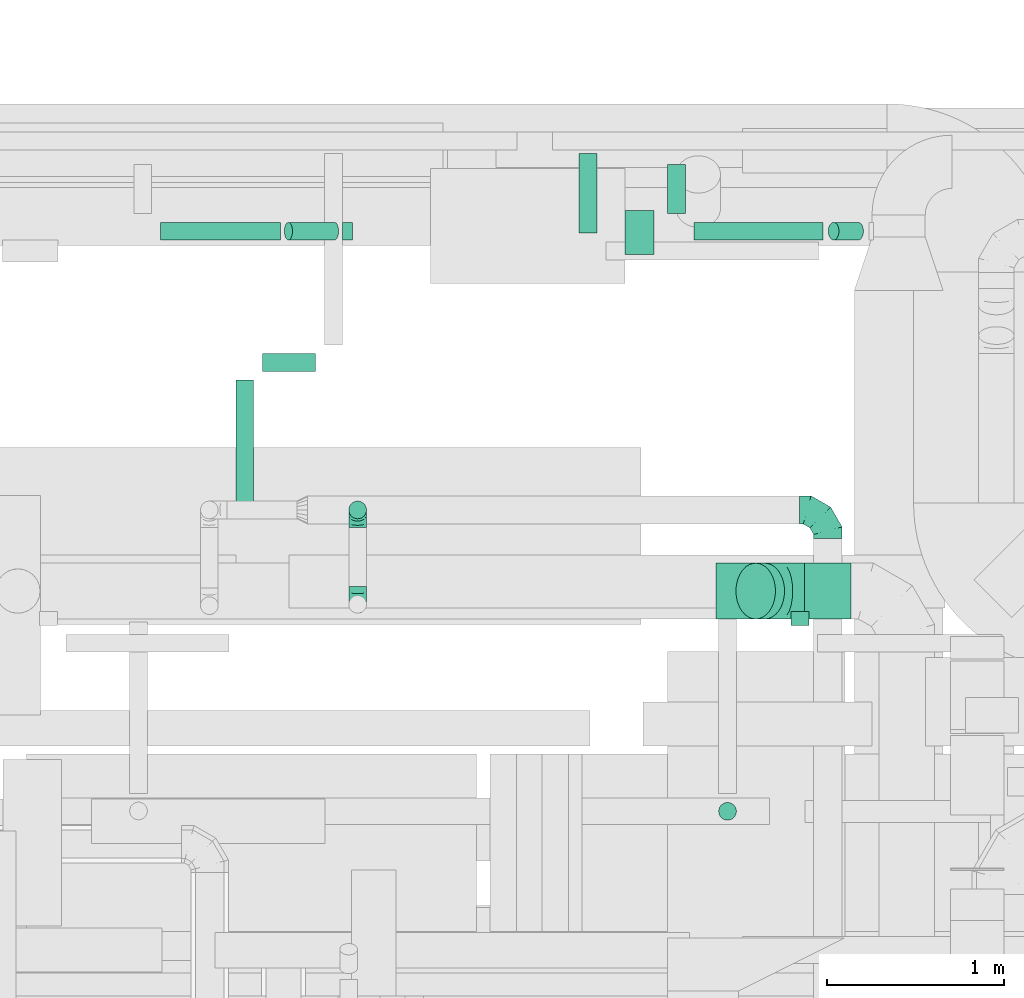
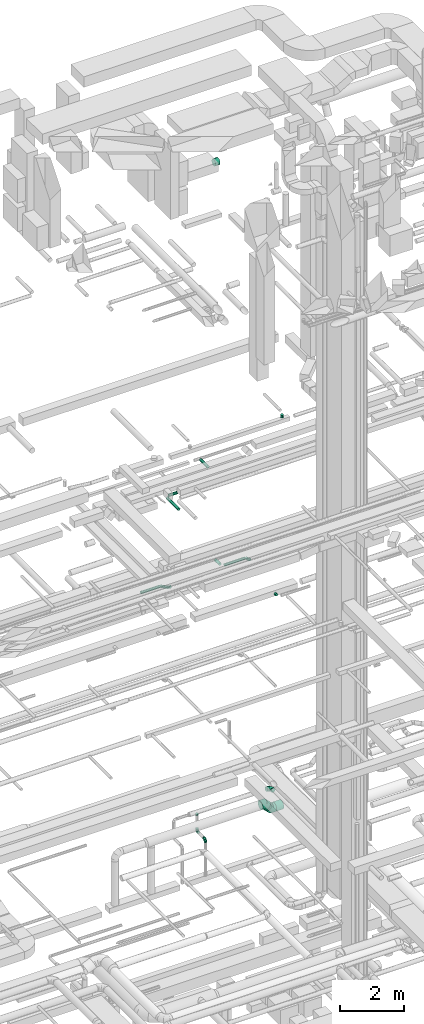
# One storey, part 277 of 337: 14 flow segments, 6 flow fittings.
"""IFC2X3 building model written with IfcOpenShell, lengths in millimetres."""

from ifc_helpers import new_model, entity, si_unit, converted_unit, derived_unit, direction, frame, origin, origin_2d_with_axis, place, context, subcontext, project, spatial, circle, extrude, faceted_brep, source, transform, mapped, material, type_object, type_shapes, element, save


model = new_model("IFC2X3")

# Units and contexts
model_context = context("Model", 3, precision=0.01, world=origin(), true_north=direction((6.12303176911189e-17, 1.0)))
body_context = subcontext(model_context, "Body", "Model", "MODEL_VIEW")
ifc_project = project(units=[si_unit("LENGTHUNIT", "METRE", prefix="MILLI"), si_unit("AREAUNIT", "SQUARE_METRE"), si_unit("VOLUMEUNIT", "CUBIC_METRE"), converted_unit("PLANEANGLEUNIT", "DEGREE", entity("IfcRatioMeasure", 0.0174532925199433), si_unit("PLANEANGLEUNIT", "RADIAN"), dimensions=[0, 0, 0, 0, 0, 0, 0]), si_unit("MASSUNIT", "GRAM", prefix="KILO"), derived_unit("MASSDENSITYUNIT", [(si_unit("MASSUNIT", "GRAM", prefix="KILO"), 1), (si_unit("LENGTHUNIT", "METRE"), -3)]), derived_unit("MOMENTOFINERTIAUNIT", [(si_unit("LENGTHUNIT", "METRE"), 4)]), si_unit("TIMEUNIT", "SECOND"), si_unit("FREQUENCYUNIT", "HERTZ"), si_unit("THERMODYNAMICTEMPERATUREUNIT", "DEGREE_CELSIUS"), derived_unit("THERMALTRANSMITTANCEUNIT", [(si_unit("MASSUNIT", "GRAM", prefix="KILO"), 1), (si_unit("THERMODYNAMICTEMPERATUREUNIT", "KELVIN"), -1), (si_unit("TIMEUNIT", "SECOND"), -3)]), derived_unit("VOLUMETRICFLOWRATEUNIT", [(si_unit("LENGTHUNIT", "METRE"), 3), (si_unit("TIMEUNIT", "SECOND"), -1)]), derived_unit("MASSFLOWRATEUNIT", [(si_unit("MASSUNIT", "GRAM", prefix="KILO"), 1), (si_unit("TIMEUNIT", "SECOND"), -1)]), derived_unit("ROTATIONALFREQUENCYUNIT", [(si_unit("TIMEUNIT", "SECOND"), -1)]), si_unit("ELECTRICCURRENTUNIT", "AMPERE"), si_unit("ELECTRICVOLTAGEUNIT", "VOLT"), si_unit("POWERUNIT", "WATT"), si_unit("FORCEUNIT", "NEWTON", prefix="KILO"), si_unit("ILLUMINANCEUNIT", "LUX"), si_unit("LUMINOUSFLUXUNIT", "LUMEN"), si_unit("LUMINOUSINTENSITYUNIT", "CANDELA"), derived_unit("USERDEFINED", [(si_unit("MASSUNIT", "GRAM", prefix="KILO"), -1), (si_unit("LENGTHUNIT", "METRE"), -2), (si_unit("TIMEUNIT", "SECOND"), 3), (si_unit("LUMINOUSFLUXUNIT", "LUMEN"), 1)]), derived_unit("LINEARVELOCITYUNIT", [(si_unit("LENGTHUNIT", "METRE"), 1), (si_unit("TIMEUNIT", "SECOND"), -1)]), si_unit("PRESSUREUNIT", "PASCAL"), derived_unit("USERDEFINED", [(si_unit("LENGTHUNIT", "METRE"), -2), (si_unit("MASSUNIT", "GRAM", prefix="KILO"), 1), (si_unit("TIMEUNIT", "SECOND"), -2)]), derived_unit("LINEARFORCEUNIT", [(si_unit("MASSUNIT", "GRAM", prefix="KILO"), 1), (si_unit("LENGTHUNIT", "METRE"), 1), (si_unit("TIMEUNIT", "SECOND"), -2), (si_unit("LENGTHUNIT", "METRE"), -1)]), derived_unit("PLANARFORCEUNIT", [(si_unit("MASSUNIT", "GRAM", prefix="KILO"), 1), (si_unit("LENGTHUNIT", "METRE"), 1), (si_unit("TIMEUNIT", "SECOND"), -2), (si_unit("LENGTHUNIT", "METRE"), -2)])], contexts=[model_context])

# Site, building, storey
site_placement = place(None, origin())
site = spatial("IfcSite", under=ifc_project, at=site_placement, CompositionType="ELEMENT")
building_placement = place(site_placement, origin())
building = spatial("IfcBuilding", under=site, at=building_placement, CompositionType="ELEMENT")
storey_placement = place(building_placement, origin())
storey = spatial("IfcBuildingStorey", under=building, at=storey_placement, CompositionType="ELEMENT", Elevation=0.0)

# Flow segments
duct_segment_type = type_object("IfcDuctSegmentType", PredefinedType="NOTDEFINED")
flow_segment_1_placement = place(storey_placement, frame((42161.52, 19353.19, 11348.4)))
element("IfcFlowSegment", 1, at=flow_segment_1_placement, inside=storey, type_object=duct_segment_type, context=body_context, shape_type="SweptSolid", body=[
    extrude(circle(Radius=50.0, at=origin_2d_with_axis()), frame((0.0, 51.6, 51.6), z_axis=(1.0, 0.0, 0.0), x_axis=(0.0, 1.0, 0.0)), (0.0, 0.0, 1.0), 675.992124092019),
])
flow_segment_2_placement = place(storey_placement, frame((45172.26, 19353.19, 11348.4)))
element("IfcFlowSegment", 2, at=flow_segment_2_placement, inside=storey, type_object=duct_segment_type, context=body_context, shape_type="SweptSolid", body=[
    extrude(circle(Radius=50.0, at=origin_2d_with_axis()), frame((0.0, 51.6, 51.6), z_axis=(1.0, 0.0, 0.0), x_axis=(0.0, 1.0, 0.0)), (0.0, 0.0, 1.0), 726.540468049814),
])
flow_segment_3_placement = place(storey_placement, frame((42858.61, 19353.19, 11210.4)))
element("IfcFlowSegment", 3, at=flow_segment_3_placement, inside=storey, type_object=duct_segment_type, context=body_context, shape_type="SweptSolid", body=[
    extrude(circle(Radius=50.0, at=origin_2d_with_axis()), frame((284.45, 51.6, 46.15), z_axis=(-0.891006524188362, 0.0, 0.453990499739558), x_axis=(0.0, -1.0, 0.0)), (0.0, 0.0, 1.0), 291.984248184055),
])
flow_segment_4_placement = place(storey_placement, frame((43188.47, 19353.19, 11194.05)))
element("IfcFlowSegment", 4, at=flow_segment_4_placement, inside=storey, type_object=duct_segment_type, context=body_context, shape_type="SweptSolid", body=[
    extrude(circle(Radius=50.0, at=origin_2d_with_axis()), frame((0.0, 51.6, 51.6), z_axis=(1.0, 0.0, 0.0), x_axis=(0.0, -1.0, 0.0)), (0.0, 0.0, 1.0), 55.9921240919866),
])
flow_segment_5_placement = place(storey_placement, frame((45927.3, 19353.19, 11234.17)))
element("IfcFlowSegment", 5, at=flow_segment_5_placement, inside=storey, type_object=duct_segment_type, context=body_context, shape_type="SweptSolid", body=[
    extrude(circle(Radius=50.0, at=origin_2d_with_axis()), frame((31.69, 51.6, 145.69), z_axis=(0.798635510047299, 0.0, -0.601815023152041), x_axis=(0.0, -1.0, 0.0)), (0.0, 0.0, 1.0), 173.080936099639),
])
flow_segment_6_placement = place(storey_placement, frame((45717.14, 17179.24, 11348.4)))
element("IfcFlowSegment", 6, at=flow_segment_6_placement, inside=storey, type_object=duct_segment_type, context=body_context, shape_type="SweptSolid", body=[
    extrude(circle(Radius=50.0, at=origin_2d_with_axis()), frame((51.6, 0.0, 51.6), z_axis=(0.0, 1.0, 0.0), x_axis=(1.0, 0.0, 0.0)), (0.0, 0.0, 1.0), 78.8689395275577),
])
flow_segment_7_placement = place(storey_placement, frame((45020.67, 19504.79, 11348.4)))
element("IfcFlowSegment", 7, at=flow_segment_7_placement, inside=storey, type_object=duct_segment_type, context=body_context, shape_type="SweptSolid", body=[
    extrude(circle(Radius=50.0, at=origin_2d_with_axis()), frame((51.6, 0.0, 51.6), z_axis=(0.0, 1.0, 0.0), x_axis=(-1.0, 0.0, 0.0)), (0.0, 0.0, 1.0), 276.269796034371),
])
flow_segment_8_placement = place(storey_placement, frame((45308.75, 16079.91, 18945.0)))
element("IfcFlowSegment", 8, at=flow_segment_8_placement, inside=storey, type_object=duct_segment_type, context=body_context, shape_type="SweptSolid", body=[
    extrude(circle(Radius=50.0, at=origin_2d_with_axis()), frame((51.6, 51.6, 0.0), z_axis=(0.0, 0.0, 1.0), x_axis=(-1.0, 0.0, 0.0)), (0.0, 0.0, 1.0), 105.000189891296),
])
flow_segment_9_placement = place(storey_placement, frame((42736.87, 18612.29, 15298.4)))
element("IfcFlowSegment", 9, at=flow_segment_9_placement, inside=storey, type_object=duct_segment_type, context=body_context, shape_type="SweptSolid", body=[
    extrude(circle(Radius=50.0, at=origin_2d_with_axis()), frame((0.0, 51.6, 51.6), z_axis=(1.0, 0.0, 0.0), x_axis=(0.0, 1.0, 0.0)), (0.0, 0.0, 1.0), 300.00000000001),
])
flow_segment_10_placement = place(storey_placement, frame((42585.27, 17851.62, 15298.4)))
element("IfcFlowSegment", 10, at=flow_segment_10_placement, inside=storey, type_object=duct_segment_type, context=body_context, shape_type="SweptSolid", body=[
    extrude(circle(Radius=50.0, at=origin_2d_with_axis()), frame((51.6, 0.0, 51.6), z_axis=(0.0, 1.0, 0.0), x_axis=(-1.0, 0.0, 0.0)), (0.0, 0.0, 1.0), 712.263912534199),
])
flow_segment_11_placement = place(storey_placement, frame((44521.8, 19393.29, 15298.4)))
element("IfcFlowSegment", 11, at=flow_segment_11_placement, inside=storey, type_object=duct_segment_type, context=body_context, shape_type="SweptSolid", body=[
    extrude(circle(Radius=50.0, at=origin_2d_with_axis()), frame((51.6, 0.0, 51.6), z_axis=(0.0, 1.0, 0.0), x_axis=(-1.0, 0.0, 0.0)), (0.0, 0.0, 1.0), 450.592242668026),
])
flow_segment_12_placement = place(storey_placement, frame((44783.2, 19271.72, 26748.95)))
element("IfcFlowSegment", 12, at=flow_segment_12_placement, inside=storey, type_object=duct_segment_type, context=body_context, shape_type="SweptSolid", body=[
    extrude(circle(Radius=125.0, at=origin_2d_with_axis()), frame((0.0, 126.05, 126.05), z_axis=(1.0, 0.0, 0.0), x_axis=(0.0, 0.937425272009763, -0.348186529603635)), (0.0, 0.0, 1.0), 162.499999999911),
])
flow_segment_13_placement = place(storey_placement, frame((45793.37, 17215.18, 3040.9)))
element("IfcFlowSegment", 13, at=flow_segment_13_placement, inside=storey, type_object=duct_segment_type, context=body_context, shape_type="SweptSolid", body=[
    extrude(circle(Radius=157.5, at=origin_2d_with_axis()), frame((0.0, 159.1, 159.1), z_axis=(1.0, 0.0, 0.0), x_axis=(0.0, 1.0, 0.0)), (0.0, 0.0, 1.0), 263.219916552418),
])
flow_segment_14_placement = place(storey_placement, frame((45406.37, 17215.18, 3179.3)))
element("IfcFlowSegment", 14, at=flow_segment_14_placement, inside=storey, type_object=duct_segment_type, context=body_context, shape_type="SweptSolid", body=[
    extrude(circle(Radius=157.5, at=origin_2d_with_axis()), frame((164.26, 159.1, 112.96), z_axis=(-0.707106792500036, 0.0, 0.707106769873059), x_axis=(0.0, 1.0, 0.0)), (0.0, 0.0, 1.0), 72.543986600266),
])

# Flow fittings
ifc_material = material()
duct_fitting_type_1 = type_object("IfcDuctFittingType", PredefinedType="NOTDEFINED", material=ifc_material)
shared_shape_1 = source(origin(), body_context, "Body", "Brep", [
    faceted_brep([(-160.0, 0.0, -80.0), (-160.0, -20.71, -77.27), (-160.0, -40.0, -69.28), (-160.0, -56.57, -56.57), (-160.0, -69.28, -40.0), (-160.0, -77.27, -20.71), (-160.0, -80.0, 0.0), (-160.0, -77.27, 20.71), (-160.0, -69.28, 40.0), (-160.0, -56.57, 56.57), (-160.0, -40.0, 69.28), (-160.0, -20.71, 77.27), (-160.0, 0.0, 80.0), (-160.0, 20.71, 77.27), (-160.0, 40.0, 69.28), (-160.0, 56.57, 56.57), (-160.0, 69.28, 40.0), (-160.0, 77.27, 20.71), (-160.0, 80.0, 0.0), (-160.0, 77.27, -20.71), (-160.0, 69.28, -40.0), (-160.0, 56.57, -56.57), (-160.0, 40.0, -69.28), (-160.0, 20.71, -77.27), (-122.68, 20.71, 77.27), (-127.85, 40.0, 69.28), (-117.13, 0.0, 80.0), (-132.29, 56.57, 56.57), (-137.83, 77.27, 20.71), (-138.56, 80.0, 0.0), (-135.69, 69.28, 40.0), (-135.69, 69.28, -40.0), (-132.29, 56.57, -56.57), (-137.83, 77.27, -20.71), (-122.68, 20.71, -77.27), (-117.13, 0.0, -80.0), (-127.85, 40.0, -69.28), (-111.58, -20.71, -77.27), (-106.41, -40.0, -69.28), (-101.97, -56.57, -56.57), (-98.56, -69.28, -40.0), (-96.42, -77.27, -20.71), (-95.69, -80.0, 0.0), (-96.42, -77.27, 20.71), (-98.56, -69.28, 40.0), (-101.97, -56.57, 56.57), (-106.41, -40.0, 69.28), (-111.58, -20.71, 77.27), (-58.03, 58.03, 77.27), (-72.15, 72.15, 69.28), (-42.87, 42.87, 80.0), (-84.28, 84.28, 56.57), (-93.59, 93.59, 40.0), (-99.44, 99.44, 20.71), (-101.44, 101.44, 0.0), (-99.44, 99.44, -20.71), (-93.59, 93.59, -40.0), (-84.28, 84.28, -56.57), (-58.03, 58.03, -77.27), (-42.87, 42.87, -80.0), (-72.15, 72.15, -69.28), (-27.71, 27.71, -77.27), (-13.59, 13.59, -69.28), (-1.46, 1.46, -56.57), (7.85, -7.85, -40.0), (13.7, -13.7, -20.71), (15.69, -15.69, 0.0), (13.7, -13.7, 20.71), (7.85, -7.85, 40.0), (-1.46, 1.46, 56.57), (-13.59, 13.59, 69.28), (-27.71, 27.71, 77.27), (-20.71, 122.68, 77.27), (-40.0, 127.85, 69.28), (0.0, 117.13, 80.0), (-56.57, 132.29, 56.57), (-69.28, 135.69, 40.0), (-77.27, 137.83, 20.71), (-80.0, 138.56, 0.0), (-77.27, 137.83, -20.71), (-69.28, 135.69, -40.0), (-56.57, 132.29, -56.57), (-20.71, 122.68, -77.27), (0.0, 117.13, -80.0), (-40.0, 127.85, -69.28), (20.71, 111.58, -77.27), (40.0, 106.41, -69.28), (56.57, 101.97, -56.57), (69.28, 98.56, -40.0), (77.27, 96.42, -20.71), (80.0, 95.69, 0.0), (77.27, 96.42, 20.71), (69.28, 98.56, 40.0), (56.57, 101.97, 56.57), (40.0, 106.41, 69.28), (20.71, 111.58, 77.27), (-20.71, 160.0, -77.27), (-40.0, 160.0, -69.28), (-56.57, 160.0, -56.57), (-69.28, 160.0, -40.0), (-77.27, 160.0, -20.71), (-80.0, 160.0, 0.0), (-77.27, 160.0, 20.71), (-69.28, 160.0, 40.0), (-56.57, 160.0, 56.57), (-40.0, 160.0, 69.28), (-20.71, 160.0, 77.27), (0.0, 160.0, 80.0), (20.71, 160.0, 77.27), (40.0, 160.0, 69.28), (56.57, 160.0, 56.57), (69.28, 160.0, 40.0), (77.27, 160.0, 20.71), (80.0, 160.0, 0.0), (77.27, 160.0, -20.71), (69.28, 160.0, -40.0), (56.57, 160.0, -56.57), (40.0, 160.0, -69.28), (20.71, 160.0, -77.27), (0.0, 160.0, -80.0)], [[[0, 1, 2, 3, 4, 5, 6, 7, 8, 9, 10, 11, 12, 13, 14, 15, 16, 17, 18, 19, 20, 21, 22, 23]], [[24, 25, 14, 13]], [[26, 24, 13, 12]], [[14, 25, 27, 15]], [[28, 29, 18, 17]], [[30, 28, 17, 16]], [[15, 27, 30, 16]], [[20, 31, 32, 21]], [[33, 31, 20, 19]], [[18, 29, 33, 19]], [[34, 35, 0, 23]], [[36, 34, 23, 22]], [[32, 36, 22, 21]], [[1, 0, 35, 37]], [[2, 1, 37, 38]], [[3, 2, 38, 39]], [[5, 4, 40, 41]], [[6, 5, 41, 42]], [[39, 40, 4, 3]], [[6, 42, 43, 7]], [[7, 43, 44, 8]], [[8, 44, 45, 9]], [[9, 45, 46, 10]], [[10, 46, 47, 11]], [[26, 12, 11, 47]], [[48, 49, 25, 24]], [[50, 48, 24, 26]], [[27, 25, 49, 51]], [[52, 53, 28, 30]], [[51, 52, 30, 27]], [[29, 28, 53, 54]], [[55, 56, 31, 33]], [[54, 55, 33, 29]], [[32, 31, 56, 57]], [[58, 59, 35, 34]], [[60, 58, 34, 36]], [[57, 60, 36, 32]], [[37, 35, 59, 61]], [[38, 37, 61, 62]], [[39, 38, 62, 63]], [[41, 40, 64, 65]], [[42, 41, 65, 66]], [[63, 64, 40, 39]], [[43, 42, 66, 67]], [[44, 43, 67, 68]], [[68, 69, 45, 44]], [[46, 45, 69, 70]], [[47, 46, 70, 71]], [[26, 47, 71, 50]], [[72, 73, 49, 48]], [[74, 72, 48, 50]], [[51, 49, 73, 75]], [[76, 77, 53, 52]], [[75, 76, 52, 51]], [[54, 53, 77, 78]], [[79, 80, 56, 55]], [[78, 79, 55, 54]], [[57, 56, 80, 81]], [[82, 83, 59, 58]], [[84, 82, 58, 60]], [[81, 84, 60, 57]], [[61, 59, 83, 85]], [[62, 61, 85, 86]], [[63, 62, 86, 87]], [[65, 64, 88, 89]], [[66, 65, 89, 90]], [[87, 88, 64, 63]], [[67, 66, 90, 91]], [[68, 67, 91, 92]], [[92, 93, 69, 68]], [[70, 69, 93, 94]], [[71, 70, 94, 95]], [[50, 71, 95, 74]], [[96, 97, 98, 99, 100, 101, 102, 103, 104, 105, 106, 107, 108, 109, 110, 111, 112, 113, 114, 115, 116, 117, 118, 119]], [[72, 74, 107, 106]], [[73, 72, 106, 105]], [[75, 73, 105, 104]], [[77, 76, 103, 102]], [[78, 77, 102, 101]], [[75, 104, 103, 76]], [[78, 101, 100, 79]], [[79, 100, 99, 80]], [[80, 99, 98, 81]], [[84, 97, 96, 82]], [[82, 96, 119, 83]], [[84, 81, 98, 97]], [[118, 117, 86, 85]], [[119, 118, 85, 83]], [[116, 87, 86, 117]], [[88, 115, 114, 89]], [[89, 114, 113, 90]], [[115, 88, 87, 116]], [[112, 111, 92, 91]], [[113, 112, 91, 90]], [[111, 110, 93, 92]], [[95, 94, 109, 108]], [[74, 95, 108, 107]], [[110, 109, 94, 93]]]),
])
type_shapes(duct_fitting_type_1, [shared_shape_1])
flow_fitting_1_placement = place(storey_placement, frame((45926.64, 17831.97, 3600.0), z_axis=(0.0, 0.0, 1.0), x_axis=(0.0, 1.0, 0.0)))
element("IfcFlowFitting", 15, at=flow_fitting_1_placement, inside=storey, type_object=duct_fitting_type_1, material=ifc_material, context=body_context, shape_type="MappedRepresentation", body=[
    mapped(shared_shape_1, transform((0.0, 0.0, 0.0), scale=1.0)),
])
duct_fitting_type_2 = type_object("IfcDuctFittingType", PredefinedType="NOTDEFINED", material=ifc_material)
shared_shape_2 = source(origin(), body_context, "Body", "Brep", [
    faceted_brep([(-100.0, 0.0, -50.0), (-100.0, -12.94, -48.3), (-100.0, -25.0, -43.3), (-100.0, -35.36, -35.36), (-100.0, -43.3, -25.0), (-100.0, -48.3, -12.94), (-100.0, -50.0, 0.0), (-100.0, -48.3, 12.94), (-100.0, -43.3, 25.0), (-100.0, -35.36, 35.36), (-100.0, -25.0, 43.3), (-100.0, -12.94, 48.3), (-100.0, 0.0, 50.0), (-100.0, 12.94, 48.3), (-100.0, 25.0, 43.3), (-100.0, 35.36, 35.36), (-100.0, 43.3, 25.0), (-100.0, 48.3, 12.94), (-100.0, 50.0, 0.0), (-100.0, 48.3, -12.94), (-100.0, 43.3, -25.0), (-100.0, 35.36, -35.36), (-100.0, 25.0, -43.3), (-100.0, 12.94, -48.3), (-76.67, 12.94, 48.3), (-79.9, 25.0, 43.3), (-73.21, 0.0, 50.0), (-82.68, 35.36, 35.36), (-86.15, 48.3, 12.94), (-86.6, 50.0, 0.0), (-84.81, 43.3, 25.0), (-84.81, 43.3, -25.0), (-82.68, 35.36, -35.36), (-86.15, 48.3, -12.94), (-76.67, 12.94, -48.3), (-73.21, 0.0, -50.0), (-79.9, 25.0, -43.3), (-69.74, -12.94, -48.3), (-66.51, -25.0, -43.3), (-63.73, -35.36, -35.36), (-61.6, -43.3, -25.0), (-60.26, -48.3, -12.94), (-59.81, -50.0, 0.0), (-60.26, -48.3, 12.94), (-61.6, -43.3, 25.0), (-63.73, -35.36, 35.36), (-66.51, -25.0, 43.3), (-69.74, -12.94, 48.3), (-36.27, 36.27, 48.3), (-45.1, 45.1, 43.3), (-26.79, 26.79, 50.0), (-52.68, 52.68, 35.36), (-58.49, 58.49, 25.0), (-62.15, 62.15, 12.94), (-63.4, 63.4, 0.0), (-62.15, 62.15, -12.94), (-58.49, 58.49, -25.0), (-52.68, 52.68, -35.36), (-36.27, 36.27, -48.3), (-26.79, 26.79, -50.0), (-45.1, 45.1, -43.3), (-17.32, 17.32, -48.3), (-8.49, 8.49, -43.3), (-0.91, 0.91, -35.36), (4.9, -4.9, -25.0), (8.56, -8.56, -12.94), (9.81, -9.81, 0.0), (8.56, -8.56, 12.94), (4.9, -4.9, 25.0), (-0.91, 0.91, 35.36), (-8.49, 8.49, 43.3), (-17.32, 17.32, 48.3), (-12.94, 76.67, 48.3), (-25.0, 79.9, 43.3), (0.0, 73.21, 50.0), (-35.36, 82.68, 35.36), (-43.3, 84.81, 25.0), (-48.3, 86.15, 12.94), (-50.0, 86.6, 0.0), (-48.3, 86.15, -12.94), (-43.3, 84.81, -25.0), (-35.36, 82.68, -35.36), (-12.94, 76.67, -48.3), (0.0, 73.21, -50.0), (-25.0, 79.9, -43.3), (12.94, 69.74, -48.3), (25.0, 66.51, -43.3), (35.36, 63.73, -35.36), (43.3, 61.6, -25.0), (48.3, 60.26, -12.94), (50.0, 59.81, 0.0), (48.3, 60.26, 12.94), (43.3, 61.6, 25.0), (35.36, 63.73, 35.36), (25.0, 66.51, 43.3), (12.94, 69.74, 48.3), (-12.94, 100.0, -48.3), (-25.0, 100.0, -43.3), (-35.36, 100.0, -35.36), (-43.3, 100.0, -25.0), (-48.3, 100.0, -12.94), (-50.0, 100.0, 0.0), (-48.3, 100.0, 12.94), (-43.3, 100.0, 25.0), (-35.36, 100.0, 35.36), (-25.0, 100.0, 43.3), (-12.94, 100.0, 48.3), (0.0, 100.0, 50.0), (12.94, 100.0, 48.3), (25.0, 100.0, 43.3), (35.36, 100.0, 35.36), (43.3, 100.0, 25.0), (48.3, 100.0, 12.94), (50.0, 100.0, 0.0), (48.3, 100.0, -12.94), (43.3, 100.0, -25.0), (35.36, 100.0, -35.36), (25.0, 100.0, -43.3), (12.94, 100.0, -48.3), (0.0, 100.0, -50.0)], [[[0, 1, 2, 3, 4, 5, 6, 7, 8, 9, 10, 11, 12, 13, 14, 15, 16, 17, 18, 19, 20, 21, 22, 23]], [[24, 25, 14, 13]], [[26, 24, 13, 12]], [[14, 25, 27, 15]], [[28, 29, 18, 17]], [[30, 28, 17, 16]], [[15, 27, 30, 16]], [[20, 31, 32, 21]], [[33, 31, 20, 19]], [[18, 29, 33, 19]], [[34, 35, 0, 23]], [[36, 34, 23, 22]], [[32, 36, 22, 21]], [[2, 1, 37, 38]], [[3, 2, 38, 39]], [[0, 35, 37, 1]], [[5, 4, 40, 41]], [[6, 5, 41, 42]], [[3, 39, 40, 4]], [[6, 42, 43, 7]], [[7, 43, 44, 8]], [[8, 44, 45, 9]], [[10, 46, 47, 11]], [[11, 47, 26, 12]], [[10, 9, 45, 46]], [[48, 49, 25, 24]], [[50, 48, 24, 26]], [[27, 25, 49, 51]], [[52, 53, 28, 30]], [[51, 52, 30, 27]], [[29, 28, 53, 54]], [[55, 56, 31, 33]], [[54, 55, 33, 29]], [[57, 32, 31, 56]], [[58, 59, 35, 34]], [[60, 58, 34, 36]], [[57, 60, 36, 32]], [[37, 35, 59, 61]], [[38, 37, 61, 62]], [[39, 38, 62, 63]], [[41, 40, 64, 65]], [[42, 41, 65, 66]], [[63, 64, 40, 39]], [[43, 42, 66, 67]], [[44, 43, 67, 68]], [[68, 69, 45, 44]], [[46, 45, 69, 70]], [[47, 46, 70, 71]], [[26, 47, 71, 50]], [[72, 73, 49, 48]], [[74, 72, 48, 50]], [[51, 49, 73, 75]], [[76, 77, 53, 52]], [[75, 76, 52, 51]], [[54, 53, 77, 78]], [[79, 80, 56, 55]], [[78, 79, 55, 54]], [[81, 57, 56, 80]], [[82, 83, 59, 58]], [[84, 82, 58, 60]], [[81, 84, 60, 57]], [[61, 59, 83, 85]], [[62, 61, 85, 86]], [[63, 62, 86, 87]], [[65, 64, 88, 89]], [[66, 65, 89, 90]], [[87, 88, 64, 63]], [[67, 66, 90, 91]], [[68, 67, 91, 92]], [[92, 93, 69, 68]], [[70, 69, 93, 94]], [[71, 70, 94, 95]], [[50, 71, 95, 74]], [[96, 97, 98, 99, 100, 101, 102, 103, 104, 105, 106, 107, 108, 109, 110, 111, 112, 113, 114, 115, 116, 117, 118, 119]], [[72, 74, 107, 106]], [[73, 72, 106, 105]], [[75, 73, 105, 104]], [[77, 76, 103, 102]], [[78, 77, 102, 101]], [[75, 104, 103, 76]], [[78, 101, 100, 79]], [[79, 100, 99, 80]], [[80, 99, 98, 81]], [[96, 119, 83, 82]], [[97, 96, 82, 84]], [[84, 81, 98, 97]], [[83, 119, 118, 85]], [[85, 118, 117, 86]], [[86, 117, 116, 87]], [[88, 115, 114, 89]], [[89, 114, 113, 90]], [[87, 116, 115, 88]], [[91, 90, 113, 112]], [[92, 91, 112, 111]], [[93, 92, 111, 110]], [[95, 94, 109, 108]], [[74, 95, 108, 107]], [[110, 109, 94, 93]]]),
])
type_shapes(duct_fitting_type_2, [shared_shape_2])
for number, where, z_axis, x_axis in (
    (16, (43273.54, 17831.97, 2885.0), (-1.0, 0.0, 0.0), (0.0, 0.0, -1.0)),
    (17, (43273.54, 17299.47, 2885.0), (1.0, 0.0, 0.0), (0.0, -1.0, 0.0)),
):
    element("IfcFlowFitting", number, at=place(storey_placement, frame(where, z_axis=z_axis, x_axis=x_axis)), inside=storey, type_object=duct_fitting_type_2, material=ifc_material, context=body_context, shape_type="MappedRepresentation", body=[
        mapped(shared_shape_2, transform((0.0, 0.0, 0.0), scale=1.0)),
    ])
duct_fitting_type_3 = type_object("IfcDuctFittingType", PredefinedType="NOTDEFINED", material=ifc_material)
shared_shape_3 = source(origin(), body_context, "Body", "Brep", [
    faceted_brep([(20.0, 0.0, -50.0), (20.0, 12.94, -48.3), (20.0, 25.0, -43.3), (20.0, 35.36, -35.36), (20.0, 43.3, -25.0), (20.0, 48.3, -12.94), (20.0, 50.0, 0.0), (20.0, 48.3, 12.94), (20.0, 43.3, 25.0), (20.0, 35.36, 35.36), (20.0, 25.0, 43.3), (20.0, 12.94, 48.3), (20.0, 0.0, 50.0), (20.0, -12.94, 48.3), (20.0, -25.0, 43.3), (20.0, -35.36, 35.36), (20.0, -43.3, 25.0), (20.0, -48.3, 12.94), (20.0, -50.0, 0.0), (20.0, -48.3, -12.94), (20.0, -43.3, -25.0), (20.0, -35.36, -35.36), (20.0, -25.0, -43.3), (20.0, -12.94, -48.3), (0.0, 0.0, 50.0), (-23.65, 0.0, 50.0), (-23.65, -12.94, 48.3), (0.0, -12.94, 48.3), (-23.65, -25.0, 43.3), (0.0, -25.0, 43.3), (0.0, -35.36, 35.36), (-23.65, -35.36, 35.36), (0.0, -43.3, 25.0), (-23.65, -43.3, 25.0), (-23.65, -48.3, 12.94), (0.0, -48.3, 12.94), (-23.65, -50.0, 0.0), (0.0, -50.0, 0.0), (-23.65, -48.3, -12.94), (0.0, -48.3, -12.94), (-23.65, -43.3, -25.0), (0.0, -43.3, -25.0), (0.0, -35.36, -35.36), (-23.65, -35.36, -35.36), (0.0, -25.0, -43.3), (-23.65, -25.0, -43.3), (-23.65, -12.94, -48.3), (0.0, -12.94, -48.3), (-23.65, 0.0, -50.0), (0.0, 0.0, -50.0), (-23.65, 12.94, -48.3), (0.0, 12.94, -48.3), (-23.65, 25.0, -43.3), (0.0, 25.0, -43.3), (0.0, 35.36, -35.36), (-23.65, 35.36, -35.36), (0.0, 43.3, -25.0), (-23.65, 43.3, -25.0), (-23.65, 48.3, -12.94), (0.0, 48.3, -12.94), (-23.65, 50.0, 0.0), (0.0, 50.0, 0.0), (-23.65, 48.3, 12.94), (0.0, 48.3, 12.94), (-23.65, 43.3, 25.0), (0.0, 43.3, 25.0), (0.0, 35.36, 35.36), (-23.65, 35.36, 35.36), (0.0, 25.0, 43.3), (-23.65, 25.0, 43.3), (-23.65, 12.94, 48.3), (0.0, 12.94, 48.3)], [[[0, 1, 2, 3, 4, 5, 6, 7, 8, 9, 10, 11, 12, 13, 14, 15, 16, 17, 18, 19, 20, 21, 22, 23]], [[13, 12, 24, 25, 26, 27]], [[14, 13, 27, 26, 28, 29]], [[30, 15, 14, 29, 28, 31]], [[17, 16, 32, 33, 34, 35]], [[18, 17, 35, 34, 36, 37]], [[32, 16, 15, 30, 31, 33]], [[19, 18, 37, 36, 38, 39]], [[20, 19, 39, 38, 40, 41]], [[42, 21, 20, 41, 40, 43]], [[23, 22, 44, 45, 46, 47]], [[0, 23, 47, 46, 48, 49]], [[44, 22, 21, 42, 43, 45]], [[1, 0, 49, 48, 50, 51]], [[2, 1, 51, 50, 52, 53]], [[54, 3, 2, 53, 52, 55]], [[5, 4, 56, 57, 58, 59]], [[6, 5, 59, 58, 60, 61]], [[56, 4, 3, 54, 55, 57]], [[7, 6, 61, 60, 62, 63]], [[8, 7, 63, 62, 64, 65]], [[66, 9, 8, 65, 64, 67]], [[11, 10, 68, 69, 70, 71]], [[12, 11, 71, 70, 25, 24]], [[68, 10, 9, 66, 67, 69]], [[46, 45, 43, 40, 38, 36, 34, 33, 31, 28, 26, 25, 70, 69, 67, 64, 62, 60, 58, 57, 55, 52, 50, 48]]]),
])
type_shapes(duct_fitting_type_3, [shared_shape_3])
flow_fitting_2_placement = place(storey_placement, frame((43273.54, 17831.97, 3520.0), z_axis=(-1.0, 0.0, 0.0), x_axis=(0.0, 0.0, -1.0)))
element("IfcFlowFitting", 18, at=flow_fitting_2_placement, inside=storey, type_object=duct_fitting_type_3, material=ifc_material, context=body_context, shape_type="MappedRepresentation", body=[
    mapped(shared_shape_3, transform((0.0, 0.0, 0.0), scale=1.0)),
])
duct_fitting_type_4 = type_object("IfcDuctFittingType", PredefinedType="NOTDEFINED", material=ifc_material)
shared_shape_4 = source(origin(), body_context, "Body", "Brep", [
    faceted_brep([(-130.48, 0.0, -157.5), (-130.48, -40.76, -152.13), (-130.48, -78.75, -136.4), (-130.48, -111.37, -111.37), (-130.48, -136.4, -78.75), (-130.48, -152.13, -40.76), (-130.48, -157.5, 0.0), (-130.48, -152.13, 40.76), (-130.48, -136.4, 78.75), (-130.48, -111.37, 111.37), (-130.48, -78.75, 136.4), (-130.48, -40.76, 152.13), (-130.48, 0.0, 157.5), (-130.48, 40.76, 152.13), (-130.48, 78.75, 136.4), (-130.48, 111.37, 111.37), (-130.48, 136.4, 78.75), (-130.48, 152.13, 40.76), (-130.48, 157.5, 0.0), (-130.48, 152.13, -40.76), (-130.48, 136.4, -78.75), (-130.48, 111.37, -111.37), (-130.48, 78.75, -136.4), (-130.48, 40.76, -152.13), (-16.89, 40.76, 152.13), (-32.62, 78.75, 136.4), (0.0, 0.0, 157.5), (-46.13, 111.37, 111.37), (-63.02, 152.13, 40.76), (-65.24, 157.5, 0.0), (-56.5, 136.4, 78.75), (-56.5, 136.4, -78.75), (-46.13, 111.37, -111.37), (-63.02, 152.13, -40.76), (-16.89, 40.76, -152.13), (0.0, 0.0, -157.5), (-32.62, 78.75, -136.4), (16.89, -40.76, -152.13), (32.62, -78.75, -136.4), (46.13, -111.37, -111.37), (56.5, -136.4, -78.75), (63.02, -152.13, -40.76), (65.24, -157.5, 0.0), (63.02, -152.13, 40.76), (56.5, -136.4, 78.75), (46.13, -111.37, 111.37), (32.62, -78.75, 136.4), (16.89, -40.76, 152.13), (92.26, 92.26, 157.5), (63.44, 121.09, 152.13), (36.58, 147.95, 136.4), (13.51, 171.01, 111.37), (-4.19, 188.71, 78.75), (-15.31, 199.84, 40.76), (-19.11, 203.63, 0.0), (-15.31, 199.84, -40.76), (-4.19, 188.71, -78.75), (13.51, 171.01, -111.37), (36.58, 147.95, -136.4), (63.44, 121.09, -152.13), (92.26, 92.26, -157.5), (121.09, 63.44, -152.13), (147.95, 36.58, -136.4), (171.01, 13.51, -111.37), (188.71, -4.19, -78.75), (199.84, -15.31, -40.76), (203.63, -19.11, 0.0), (199.84, -15.31, 40.76), (188.71, -4.19, 78.75), (171.01, 13.51, 111.37), (147.95, 36.58, 136.4), (121.09, 63.44, 152.13)], [[[0, 1, 2, 3, 4, 5, 6, 7, 8, 9, 10, 11, 12, 13, 14, 15, 16, 17, 18, 19, 20, 21, 22, 23]], [[24, 25, 14, 13]], [[26, 24, 13, 12]], [[14, 25, 27, 15]], [[28, 29, 18, 17]], [[30, 28, 17, 16]], [[15, 27, 30, 16]], [[20, 31, 32, 21]], [[33, 31, 20, 19]], [[18, 29, 33, 19]], [[34, 35, 0, 23]], [[36, 34, 23, 22]], [[32, 36, 22, 21]], [[1, 0, 35, 37]], [[2, 1, 37, 38]], [[38, 39, 3, 2]], [[5, 4, 40, 41]], [[6, 5, 41, 42]], [[39, 40, 4, 3]], [[6, 42, 43, 7]], [[7, 43, 44, 8]], [[8, 44, 45, 9]], [[9, 45, 46, 10]], [[10, 46, 47, 11]], [[26, 12, 11, 47]], [[24, 26, 48, 49]], [[25, 24, 49, 50]], [[27, 25, 50, 51]], [[28, 30, 52, 53]], [[29, 28, 53, 54]], [[51, 52, 30, 27]], [[55, 56, 31, 33]], [[54, 55, 33, 29]], [[57, 32, 31, 56]], [[36, 58, 59, 34]], [[34, 59, 60, 35]], [[58, 36, 32, 57]], [[35, 60, 61, 37]], [[37, 61, 62, 38]], [[63, 39, 38, 62]], [[40, 64, 65, 41]], [[41, 65, 66, 42]], [[64, 40, 39, 63]], [[43, 42, 66, 67]], [[44, 43, 67, 68]], [[68, 69, 45, 44]], [[47, 46, 70, 71]], [[26, 47, 71, 48]], [[69, 70, 46, 45]], [[59, 58, 57, 56, 55, 54, 53, 52, 51, 50, 49, 48, 71, 70, 69, 68, 67, 66, 65, 64, 63, 62, 61, 60]]]),
])
type_shapes(duct_fitting_type_4, [shared_shape_4])
for number, where, z_axis, x_axis in (
    (19, (45662.89, 17374.28, 3200.0), (0.0, 1.0, 0.0), (-1.0, 0.0, 0.0)),
    (20, (45427.07, 17374.28, 3435.82), (0.0, -1.0, 0.0), (-0.707106792499963, 0.0, 0.707106769873132)),
):
    element("IfcFlowFitting", number, at=place(storey_placement, frame(where, z_axis=z_axis, x_axis=x_axis)), inside=storey, type_object=duct_fitting_type_4, material=ifc_material, context=body_context, shape_type="MappedRepresentation", body=[
        mapped(shared_shape_4, transform((0.0, 0.0, 0.0), scale=1.0)),
    ])

save(model, "model.ifc")
